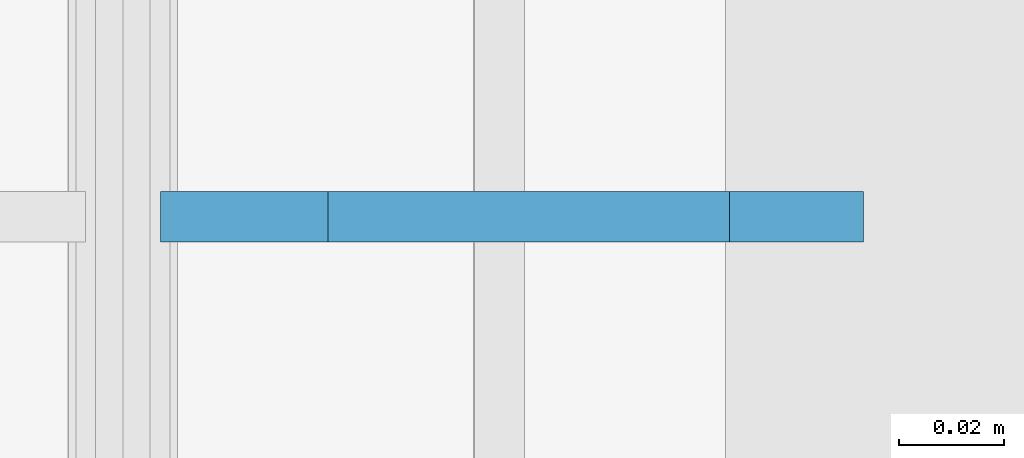
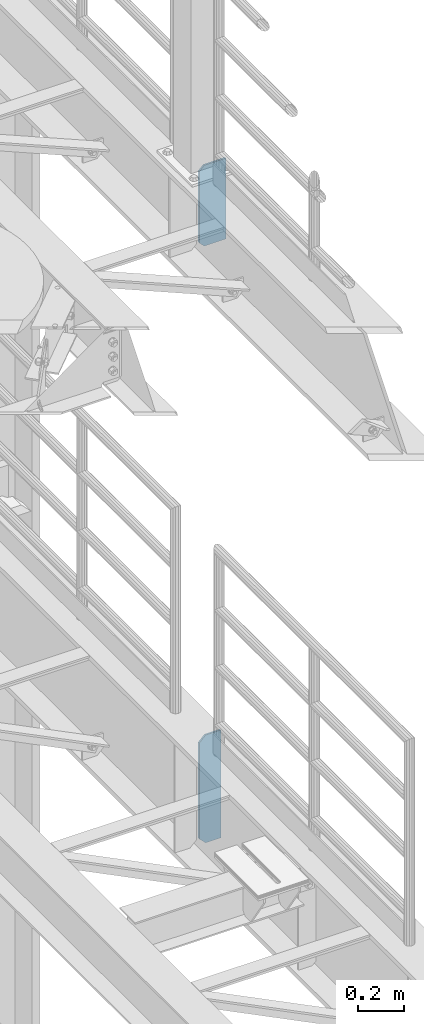
# One storey, part 1824 of 1876: 2 plates, 2 elements without a shape of their own.
"""IFC2X3 building model written with IfcOpenShell, lengths in millimetres."""

from ifc_helpers import new_model, si_unit, frame, origin_with_axes, place, context, subcontext, project, spatial, faceted_brep, material, type_object, element, aggregate, save


model = new_model("IFC2X3")

# Units and contexts
model_context = context("Model", 3, precision=1e-05, world=origin_with_axes())
body_context = subcontext(model_context, "Body", "Model", "MODEL_VIEW")
ifc_project = project(units=[si_unit("LENGTHUNIT", "METRE", prefix="MILLI"), si_unit("AREAUNIT", "SQUARE_METRE"), si_unit("VOLUMEUNIT", "CUBIC_METRE"), si_unit("MASSUNIT", "GRAM", prefix="KILO"), si_unit("TIMEUNIT", "SECOND"), si_unit("PLANEANGLEUNIT", "RADIAN"), si_unit("SOLIDANGLEUNIT", "STERADIAN"), si_unit("THERMODYNAMICTEMPERATUREUNIT", "DEGREE_CELSIUS"), si_unit("LUMINOUSINTENSITYUNIT", "LUMEN")], contexts=[model_context])

# Site, building, storey
site_placement = place(None, origin_with_axes())
site = spatial("IfcSite", under=ifc_project, at=site_placement, CompositionType="ELEMENT")
building_placement = place(site_placement, origin_with_axes())
building = spatial("IfcBuilding", under=site, at=building_placement, Name="Undefined", CompositionType="ELEMENT")
storey_placement = place(building_placement, origin_with_axes())
storey = spatial("IfcBuildingStorey", under=building, at=storey_placement, Name="Undefined", CompositionType="ELEMENT", Elevation=0.0)

# Assembly, plate
assembly_1_placement = place(storey_placement, origin_with_axes())
assembly_1 = element("IfcElementAssembly", 1, at=assembly_1_placement, inside=storey, Name="BEAM", AssemblyPlace="NOTDEFINED", PredefinedType="RIGID_FRAME")
ifc_material = material(Name="STEEL/A36")
plate_type_1 = type_object("IfcPlateType", PredefinedType="NOTDEFINED")
plate_1_placement = place(assembly_1_placement, frame((7760.49375, 11684.0, 7700.9625), z_axis=(0.0, 0.0, 1.0), x_axis=(-1.0, 0.0, 0.0)))
plate_1 = element("IfcPlate", 2, at=plate_1_placement, type_object=plate_type_1, material=ifc_material, Name="PLATE", context=body_context, shape_type="Brep", body=[
    faceted_brep([(0.0, -4.76249999999982, 0.0), (0.0, -4.76250000000073, 428.625), (0.0, 4.76250000000073, 428.625), (0.0, 4.76249999999982, 0.0), (107.950006484985, -4.76250000000073, 428.625), (107.950006484985, 4.76250000000073, 428.625), (133.350006103516, -4.76250000000073, 403.22500038147), (133.350006103516, 4.76250000000073, 403.22500038147), (133.350006103516, -4.76250000000073, 25.3999996185303), (133.350006103516, 4.76250000000073, 25.3999996185303), (107.950006484985, -4.76250000000073, 0.0), (107.950006484985, 4.76250000000073, 0.0)], [[[0, 1, 2, 3]], [[1, 4, 5, 2]], [[4, 6, 7, 5]], [[6, 8, 9, 7]], [[8, 10, 11, 9]], [[10, 0, 3, 11]], [[5, 7, 9, 11, 3, 2]], [[10, 8, 6, 4, 1, 0]]]),
])
aggregate(assembly_1, [plate_1])

assembly_2_placement = place(storey_placement, origin_with_axes())
assembly_2 = element("IfcElementAssembly", 3, at=assembly_2_placement, inside=storey, Name="BEAM", AssemblyPlace="NOTDEFINED", PredefinedType="RIGID_FRAME")
plate_type_2 = type_object("IfcPlateType", PredefinedType="NOTDEFINED")
plate_2_placement = place(assembly_2_placement, frame((7735.09375, 11684.0, 4533.9), z_axis=(0.0, 0.0, 1.0), x_axis=(-1.0, 0.0, 0.0)))
plate_2 = element("IfcPlate", 4, at=plate_2_placement, type_object=plate_type_2, material=ifc_material, Name="PLATE", context=body_context, shape_type="Brep", body=[
    faceted_brep([(0.0, -4.76249999999982, 0.0), (0.0, -4.76249999999982, 571.5), (0.0, 4.76249999999982, 571.5), (0.0, 4.76249999999982, 0.0), (76.1999969482422, -4.76249999999982, 571.5), (76.1999969482422, 4.76249999999982, 571.5), (107.949996948242, -4.76249999999982, 539.75), (107.949996948242, 4.76249999999982, 539.75), (107.949996948242, -4.76249999999982, 31.75), (107.949996948242, 4.76249999999982, 31.75), (76.1999969482422, -4.76250000000073, 0.0), (76.1999969482422, 4.76250000000073, 0.0)], [[[0, 1, 2, 3]], [[1, 4, 5, 2]], [[4, 6, 7, 5]], [[6, 8, 9, 7]], [[8, 10, 11, 9]], [[10, 0, 3, 11]], [[5, 7, 9, 11, 3, 2]], [[10, 8, 6, 4, 1, 0]]]),
])
aggregate(assembly_2, [plate_2])

save(model, "model.ifc")
